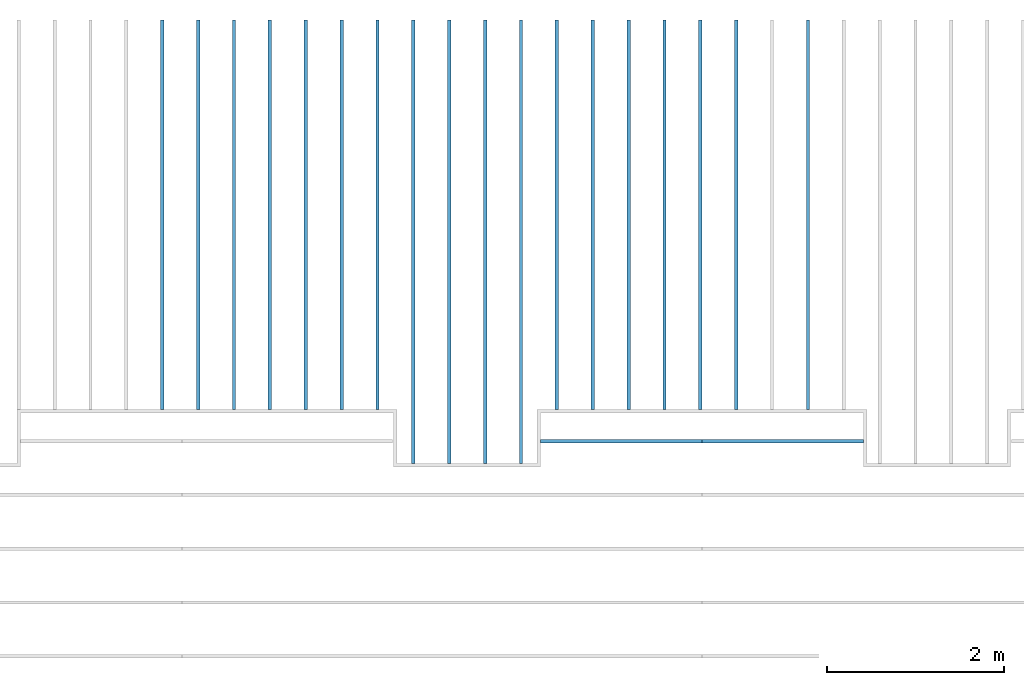
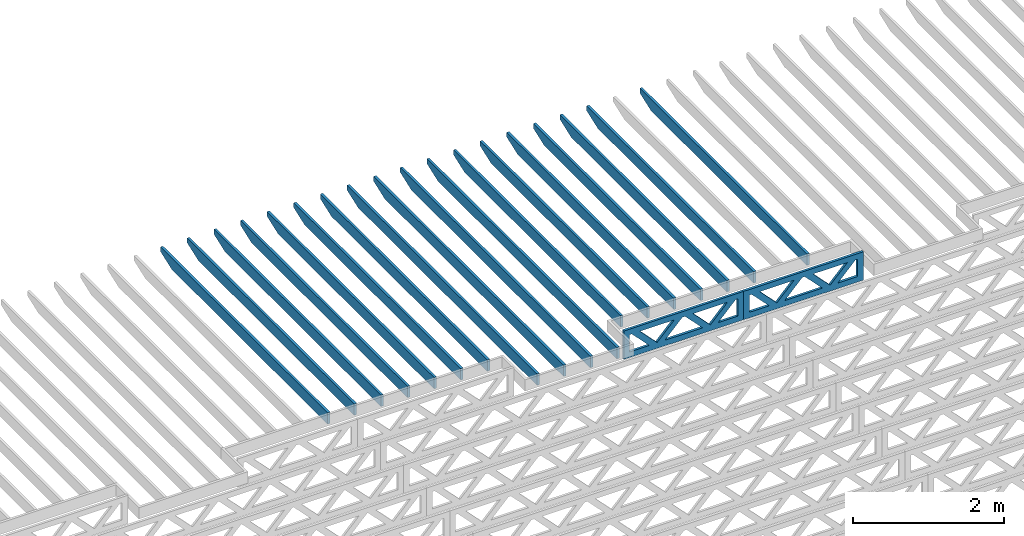
# One storey, part 6 of 18: 20 beams, 3 elements without a shape of their own.
"""IFC4 building model written with IfcOpenShell, lengths in feet."""

from ifc_helpers import new_model, entity, si_unit, converted_unit, derived_unit, direction, frame, frame_2d, origin, origin_2d_with_axis, place, context, subcontext, project, spatial, rectangle, extrude, clip, halfspace, source, transform, mapped, material, material_profile, profile_set, profile_usage, type_object, type_shapes, element, aggregate, save


model = new_model("IFC4")

# Units and contexts
model_context_1 = context("Model", 3, precision=0.0001, world=origin(), true_north=direction((6.12303176911189e-17, 1.0)))
model_context_2 = context("Model", 3, precision=0.0001, world=origin(), true_north=direction((6.12303176911189e-17, 1.0)))
body_context = subcontext(model_context_2, "Body", "Model", "MODEL_VIEW")
ifc_project = project(units=[converted_unit("LENGTHUNIT", "FOOT", entity("IfcRatioMeasure", 0.3048), si_unit("LENGTHUNIT", "METRE"), dimensions=[1, 0, 0, 0, 0, 0, 0]), converted_unit("AREAUNIT", "SQUARE FOOT", entity("IfcRatioMeasure", 0.09290304), si_unit("AREAUNIT", "SQUARE_METRE"), dimensions=[2, 0, 0, 0, 0, 0, 0]), converted_unit("VOLUMEUNIT", "CUBIC FOOT", entity("IfcRatioMeasure", 0.028316846592), si_unit("VOLUMEUNIT", "CUBIC_METRE"), dimensions=[3, 0, 0, 0, 0, 0, 0]), converted_unit("PLANEANGLEUNIT", "DEGREE", entity("IfcRatioMeasure", 0.0174532925199433), si_unit("PLANEANGLEUNIT", "RADIAN"), dimensions=[0, 0, 0, 0, 0, 0, 0]), si_unit("MASSUNIT", "GRAM", prefix="KILO"), derived_unit("MASSDENSITYUNIT", [(si_unit("MASSUNIT", "GRAM", prefix="KILO"), 1), (si_unit("LENGTHUNIT", "METRE"), -3)]), derived_unit("MOMENTOFINERTIAUNIT", [(si_unit("LENGTHUNIT", "METRE"), 4)]), si_unit("TIMEUNIT", "SECOND"), si_unit("FREQUENCYUNIT", "HERTZ"), si_unit("THERMODYNAMICTEMPERATUREUNIT", "DEGREE_CELSIUS"), derived_unit("THERMALTRANSMITTANCEUNIT", [(si_unit("MASSUNIT", "GRAM", prefix="KILO"), 1), (si_unit("THERMODYNAMICTEMPERATUREUNIT", "KELVIN"), -1), (si_unit("TIMEUNIT", "SECOND"), -3)]), derived_unit("VOLUMETRICFLOWRATEUNIT", [(si_unit("LENGTHUNIT", "METRE"), 3), (si_unit("TIMEUNIT", "SECOND"), -1)]), si_unit("ELECTRICCURRENTUNIT", "AMPERE"), si_unit("ELECTRICVOLTAGEUNIT", "VOLT"), si_unit("POWERUNIT", "WATT"), si_unit("FORCEUNIT", "NEWTON"), si_unit("ILLUMINANCEUNIT", "LUX"), si_unit("LUMINOUSFLUXUNIT", "LUMEN"), si_unit("LUMINOUSINTENSITYUNIT", "CANDELA"), derived_unit("USERDEFINED", [(si_unit("MASSUNIT", "GRAM", prefix="KILO"), -1), (si_unit("LENGTHUNIT", "METRE"), -2), (si_unit("TIMEUNIT", "SECOND"), 3), (si_unit("LUMINOUSFLUXUNIT", "LUMEN"), 1)]), derived_unit("LINEARVELOCITYUNIT", [(si_unit("LENGTHUNIT", "METRE"), 1), (si_unit("TIMEUNIT", "SECOND"), -1)]), si_unit("PRESSUREUNIT", "PASCAL"), derived_unit("USERDEFINED", [(si_unit("LENGTHUNIT", "METRE"), -2), (si_unit("MASSUNIT", "GRAM", prefix="KILO"), 1), (si_unit("TIMEUNIT", "SECOND"), -2)]), derived_unit("LINEARFORCEUNIT", [(si_unit("MASSUNIT", "GRAM", prefix="KILO"), 1), (si_unit("LENGTHUNIT", "METRE"), 1), (si_unit("TIMEUNIT", "SECOND"), -2), (si_unit("LENGTHUNIT", "METRE"), -1)]), derived_unit("PLANARFORCEUNIT", [(si_unit("MASSUNIT", "GRAM", prefix="KILO"), 1), (si_unit("LENGTHUNIT", "METRE"), 1), (si_unit("TIMEUNIT", "SECOND"), -2), (si_unit("LENGTHUNIT", "METRE"), -2)])], contexts=[model_context_1])

# Site, building, storey
site_placement = place(None, origin())
site = spatial("IfcSite", under=ifc_project, at=site_placement, CompositionType="ELEMENT")
building_placement = place(site_placement, origin())
building = spatial("IfcBuilding", under=site, at=building_placement, CompositionType="ELEMENT")
storey_placement = place(building_placement, frame((0.0, 0.0, 30.4375000000082)))
storey = spatial("IfcBuildingStorey", under=building, at=storey_placement, Name="ROOF", CompositionType="ELEMENT", Elevation=30.4375000000082)

# Assembly, beam
assembly_1_placement = place(storey_placement, origin())
assembly_1 = element("IfcElementAssembly", 1, at=assembly_1_placement, inside=storey, Name="Structural Beam System:Structural Framing System", ObjectType="Structural Beam System:Structural Framing System", AssemblyPlace="NOTDEFINED", PredefinedType="BEAM_GRID")
ifc_material_1 = material(Name="WOOD TRUSS", Category="Materials")
ifc_material_profile_1 = material_profile(ifc_material_1, rectangle(XDim=1.73473973950632, YDim=0.125, at=origin_2d_with_axis()))
ifc_material_profile_2 = material_profile(ifc_material_1, rectangle(XDim=1.73473973950633, YDim=0.125, at=frame_2d((-1.11022302462516e-16, 0.0), x_axis=(1.0, 0.0))))
ifc_material_profile_3 = material_profile(ifc_material_1, rectangle(XDim=1.73473973950632, YDim=0.125, at=origin_2d_with_axis()))
ifc_material_profile_4 = material_profile(ifc_material_1, rectangle(XDim=1.73473973950633, YDim=0.125, at=origin_2d_with_axis()))
ifc_material_profile_5 = material_profile(ifc_material_1, rectangle(XDim=1.73473973950632, YDim=0.125, at=frame_2d((-5.55111512312578e-17, 0.0), x_axis=(1.0, 0.0))))
ifc_material_profile_6 = material_profile(ifc_material_1, rectangle(XDim=1.73473973950633, YDim=0.125, at=frame_2d((-2.77555756156289e-16, 0.0), x_axis=(1.0, 0.0))))
ifc_material_profile_7 = material_profile(ifc_material_1, rectangle(XDim=1.73473973950632, YDim=0.125, at=frame_2d((-4.9960036108132e-16, 0.0), x_axis=(1.0, 0.0))))
ifc_material_profile_8 = material_profile(ifc_material_1, rectangle(XDim=1.73473973950633, YDim=0.125, at=frame_2d((4.44089209850063e-16, 0.0), x_axis=(1.0, 0.0))))
ifc_material_profile_9 = material_profile(ifc_material_1, rectangle(XDim=1.73473973950632, YDim=0.125, at=origin_2d_with_axis()))
ifc_material_profile_10 = material_profile(ifc_material_1, rectangle(XDim=1.73473973950633, YDim=0.125, at=frame_2d((-4.9960036108132e-16, 0.0), x_axis=(1.0, 0.0))))
ifc_material_profile_11 = material_profile(ifc_material_1, rectangle(XDim=0.291666666666664, YDim=0.125, at=frame_2d((-2.77555756156289e-17, 0.0), x_axis=(1.0, 0.0))))
ifc_material_profile_12 = material_profile(ifc_material_1, rectangle(XDim=0.291666666666628, YDim=0.124999999999995, at=frame_2d((-5.55111512312578e-17, 0.0), x_axis=(1.0, 0.0))))
ifc_material_profile_13 = material_profile(ifc_material_1, rectangle(XDim=0.916666666666666, YDim=0.125000000000003, at=frame_2d((-2.77555756156289e-17, 0.0), x_axis=(1.0, 0.0))))
ifc_material_profile_14 = material_profile(ifc_material_1, rectangle(XDim=0.916666666666651, YDim=0.125, at=frame_2d((-2.77555756156289e-17, 0.0), x_axis=(1.0, 0.0))))
ifc_profile_set_1 = profile_set([ifc_material_profile_1, ifc_material_profile_2, ifc_material_profile_3, ifc_material_profile_4, ifc_material_profile_5, ifc_material_profile_6, ifc_material_profile_7, ifc_material_profile_8, ifc_material_profile_9, ifc_material_profile_10, ifc_material_profile_11, ifc_material_profile_12, ifc_material_profile_13, ifc_material_profile_14])
ifc_profile_usage_1 = profile_usage(ifc_profile_set_1, cardinal=8)
beam_type_1 = type_object("IfcBeamType", PredefinedType="BEAM", material=ifc_profile_set_1)
shared_shape_1 = source(origin(), body_context, "Body", "SweptSolid", [
    extrude(rectangle(XDim=1.73473973950632, YDim=0.125, at=frame_2d((5.55111512312578e-17, 0.0), x_axis=(1.0, 0.0))), frame((1.8533931188195, 0.0, 0.101118361020515), z_axis=(0.720569184836762, 0.0, -0.693383046997606), x_axis=(0.693383046997606, 0.0, 0.720569184836762)), (0.0, 0.0, 1.0), 0.291666666666667),
    extrude(rectangle(XDim=1.73473973950633, YDim=0.125, at=frame_2d((-1.11022302462516e-16, 0.0), x_axis=(1.0, 0.0))), frame((0.603107245146231, 0.0, -0.101118361020454), z_axis=(0.720569184836758, 0.0, 0.69338304699761), x_axis=(0.69338304699761, 0.0, -0.720569184836758)), (0.0, 0.0, 1.0), 0.291666666666667),
    extrude(rectangle(XDim=1.73473973950632, YDim=0.125, at=frame_2d((-5.55111512312578e-17, 0.0), x_axis=(1.0, 0.0))), frame((-0.81327325738963, 0.0, 0.101118361020554), z_axis=(0.720569184836762, 0.0, -0.693383046997606), x_axis=(0.693383046997606, 0.0, 0.720569184836762)), (0.0, 0.0, 1.0), 0.291666666666667),
    extrude(rectangle(XDim=1.73473973950633, YDim=0.125, at=frame_2d((-1.66533453693773e-16, 0.0), x_axis=(1.0, 0.0))), frame((-2.0635591310629, 0.0, -0.101118361020415), z_axis=(0.720569184836758, 0.0, 0.69338304699761), x_axis=(0.69338304699761, 0.0, -0.720569184836758)), (0.0, 0.0, 1.0), 0.291666666666666),
    extrude(rectangle(XDim=0.291666666666664, YDim=0.125, at=frame_2d((-2.77555756156289e-17, 0.0), x_axis=(1.0, 0.0))), frame((-2.99999985477115, 0.0, 0.604166666666611), z_axis=(1.0, 0.0, 0.0), x_axis=(0.0, 0.0, -1.0)), (0.0, 0.0, 1.0), 5.99999970954229),
    extrude(rectangle(XDim=0.291666666666628, YDim=0.124999999999995, at=frame_2d((-5.55111512312578e-17, 0.0), x_axis=(1.0, 0.0))), frame((-2.99999985477093, 0.0, -0.604166666666693), z_axis=(1.0, 0.0, 0.0), x_axis=(0.0, 0.0, -1.0)), (0.0, 0.0, 1.0), 5.99999970954208),
    extrude(rectangle(XDim=0.916666666666666, YDim=0.125000000000003, at=frame_2d((-2.77555756156289e-17, 0.0), x_axis=(1.0, 0.0))), frame((2.70833318810446, 0.0, 0.0), z_axis=(1.0, 0.0, 0.0), x_axis=(0.0, 0.0, -1.0)), (0.0, 0.0, 1.0), 0.291666666666687),
    extrude(rectangle(XDim=0.916666666666651, YDim=0.125, at=frame_2d((-2.77555756156289e-17, 0.0), x_axis=(1.0, 0.0))), frame((-2.99999985477115, 0.0, 0.0), z_axis=(1.0, 0.0, 0.0), x_axis=(0.0, 0.0, -1.0)), (0.0, 0.0, 1.0), 0.291666666666687),
])
type_shapes(beam_type_1, [shared_shape_1])
beam_1_placement = place(assembly_1_placement, frame((-225.404827006933, 957.861934882651, 0.749999999991608)))
beam_1 = element("IfcBeam", 2, at=beam_1_placement, type_object=beam_type_1, material=ifc_profile_usage_1, PredefinedType="BEAM", context=body_context, shape_type="MappedRepresentation", body=[
    mapped(shared_shape_1, transform((0.0, 0.0, 0.0), scale=1.0)),
])
aggregate(assembly_1, [beam_1])

# Assembly, beams
assembly_2_placement = place(storey_placement, origin())
assembly_2 = element("IfcElementAssembly", 3, at=assembly_2_placement, inside=storey, Name="Structural Beam System:Structural Framing System", ObjectType="Structural Beam System:Structural Framing System", AssemblyPlace="NOTDEFINED", PredefinedType="BEAM_GRID")
ifc_material_2 = material(Name="2X ROOF JOISTS - EXT. STAIN-1 - SEE LIFE SAFETY", Category="Materials")
ifc_material_profile_15 = material_profile(ifc_material_2, rectangle(XDim=0.604166666666667, YDim=0.125000000000011, at=frame_2d((0.0, 0.0), x_axis=(0.0, 1.0))))
ifc_profile_set_2 = profile_set([ifc_material_profile_15])
ifc_profile_usage_2 = profile_usage(ifc_profile_set_2, cardinal=8)
beam_type_2 = type_object("IfcBeamType", PredefinedType="BEAM", material=ifc_profile_set_2)
shared_shape_2 = source(origin(), body_context, "Body", "Clipping", [
    clip(extrude(rectangle(XDim=0.604166666666667, YDim=0.125000000000011, at=frame_2d((0.0, 0.0), x_axis=(0.0, 1.0))), frame((-8.24296473987818, 0.0, 0.0), z_axis=(1.0, 0.0, 0.0), x_axis=(0.0, 1.0, 0.0)), (0.0, 0.0, 1.0), 16.4859294797564), halfspace(frame((-7.26989982048795, -0.0625000000000026, -0.30208333333334), z_axis=(-0.34202014332567, 0.0, -0.939692620785908), x_axis=(0.0, 1.0, 0.0)), False)),
])
type_shapes(beam_type_2, [shared_shape_2])
beam_2_placement = place(assembly_2_placement, frame((-233.133993818795, 965.271566289195, 1.07291666665833), z_axis=(0.0, 0.0, 1.0), x_axis=(0.0, -1.0, 0.0)))
beam_2 = element("IfcBeam", 4, at=beam_2_placement, type_object=beam_type_2, material=ifc_profile_usage_2, PredefinedType="BEAM", context=body_context, shape_type="MappedRepresentation", body=[
    mapped(shared_shape_2, transform((0.0, 0.0, 0.0), scale=1.0)),
])
ifc_profile_usage_3 = profile_usage(ifc_profile_set_2, cardinal=8)
beam_3_placement = place(assembly_2_placement, frame((-231.800660485462, 965.271566289195, 1.07291666665833), z_axis=(0.0, 0.0, 1.0), x_axis=(0.0, -1.0, 0.0)))
beam_3 = element("IfcBeam", 5, at=beam_3_placement, type_object=beam_type_2, material=ifc_profile_usage_3, PredefinedType="BEAM", context=body_context, shape_type="MappedRepresentation", body=[
    mapped(shared_shape_2, transform((0.0, 0.0, 0.0), scale=1.0)),
])
ifc_profile_usage_4 = profile_usage(ifc_profile_set_2, cardinal=8)
beam_4_placement = place(assembly_2_placement, frame((-230.467327152128, 965.271566289195, 1.07291666665833), z_axis=(0.0, 0.0, 1.0), x_axis=(0.0, -1.0, 0.0)))
beam_4 = element("IfcBeam", 6, at=beam_4_placement, type_object=beam_type_2, material=ifc_profile_usage_4, PredefinedType="BEAM", context=body_context, shape_type="MappedRepresentation", body=[
    mapped(shared_shape_2, transform((0.0, 0.0, 0.0), scale=1.0)),
])
ifc_profile_usage_5 = profile_usage(ifc_profile_set_2, cardinal=8)
beam_5_placement = place(assembly_2_placement, frame((-229.133993818795, 965.271566289195, 1.07291666665833), z_axis=(0.0, 0.0, 1.0), x_axis=(0.0, -1.0, 0.0)))
beam_5 = element("IfcBeam", 7, at=beam_5_placement, type_object=beam_type_2, material=ifc_profile_usage_5, PredefinedType="BEAM", context=body_context, shape_type="MappedRepresentation", body=[
    mapped(shared_shape_2, transform((0.0, 0.0, 0.0), scale=1.0)),
])
ifc_profile_usage_6 = profile_usage(ifc_profile_set_2, cardinal=8)
beam_type_3 = type_object("IfcBeamType", PredefinedType="BEAM", material=ifc_profile_set_2)
shared_shape_3 = source(origin(), body_context, "Body", "Clipping", [
    clip(extrude(rectangle(XDim=0.604166666666667, YDim=0.125000000000011, at=frame_2d((0.0, 0.0), x_axis=(0.0, 1.0))), frame((-7.24296400719425, 0.0, 0.0), z_axis=(1.0, 0.0, 0.0), x_axis=(0.0, 1.0, 0.0)), (0.0, 0.0, 1.0), 14.4859280143885), halfspace(frame((-6.26989908780402, -0.0625000000000026, -0.30208333333334), z_axis=(-0.34202014332567, 0.0, -0.939692620785908), x_axis=(0.0, 1.0, 0.0)), False)),
])
type_shapes(beam_type_3, [shared_shape_3])
beam_6_placement = place(assembly_2_placement, frame((-242.467327152128, 966.271567021879, 1.07291666665833), z_axis=(0.0, 0.0, 1.0), x_axis=(0.0, -1.0, 0.0)))
beam_6 = element("IfcBeam", 8, at=beam_6_placement, type_object=beam_type_3, material=ifc_profile_usage_6, PredefinedType="BEAM", context=body_context, shape_type="MappedRepresentation", body=[
    mapped(shared_shape_3, transform((0.0, 0.0, 0.0), scale=1.0)),
])
ifc_profile_usage_7 = profile_usage(ifc_profile_set_2, cardinal=8)
beam_type_4 = type_object("IfcBeamType", PredefinedType="BEAM", material=ifc_profile_set_2)
shared_shape_4 = source(origin(), body_context, "Body", "Clipping", [
    clip(extrude(rectangle(XDim=0.604166666666667, YDim=0.125000000000011, at=frame_2d((0.0, 0.0), x_axis=(0.0, 1.0))), frame((-7.24296417469543, 0.0, 0.0), z_axis=(1.0, 0.0, 0.0), x_axis=(0.0, 1.0, 0.0)), (0.0, 0.0, 1.0), 14.4859283493909), halfspace(frame((-6.2698992553052, -0.0625000000000026, -0.30208333333334), z_axis=(-0.34202014332567, 0.0, -0.939692620785908), x_axis=(0.0, 1.0, 0.0)), False)),
])
type_shapes(beam_type_4, [shared_shape_4])
beam_7_placement = place(assembly_2_placement, frame((-241.133993818795, 966.271566854378, 1.07291666665833), z_axis=(0.0, 0.0, 1.0), x_axis=(0.0, -1.0, 0.0)))
beam_7 = element("IfcBeam", 9, at=beam_7_placement, type_object=beam_type_4, material=ifc_profile_usage_7, PredefinedType="BEAM", context=body_context, shape_type="MappedRepresentation", body=[
    mapped(shared_shape_4, transform((0.0, 0.0, 0.0), scale=1.0)),
])
ifc_profile_usage_8 = profile_usage(ifc_profile_set_2, cardinal=8)
beam_type_5 = type_object("IfcBeamType", PredefinedType="BEAM", material=ifc_profile_set_2)
shared_shape_5 = source(origin(), body_context, "Body", "Clipping", [
    clip(extrude(rectangle(XDim=0.604166666666667, YDim=0.125000000000011, at=frame_2d((0.0, -5.55111512312578e-17), x_axis=(0.0, 1.0))), frame((-7.24296434219661, 0.0, 0.0), z_axis=(1.0, 0.0, 0.0), x_axis=(0.0, 1.0, 0.0)), (0.0, 0.0, 1.0), 14.4859286843932), halfspace(frame((-6.26989942280639, -0.0625000000000026, -0.30208333333334), z_axis=(-0.34202014332567, 0.0, -0.939692620785908), x_axis=(0.0, 1.0, 0.0)), False)),
])
type_shapes(beam_type_5, [shared_shape_5])
beam_8_placement = place(assembly_2_placement, frame((-239.800660485462, 966.271566686877, 1.07291666665833), z_axis=(0.0, 0.0, 1.0), x_axis=(0.0, -1.0, 0.0)))
beam_8 = element("IfcBeam", 10, at=beam_8_placement, type_object=beam_type_5, material=ifc_profile_usage_8, PredefinedType="BEAM", context=body_context, shape_type="MappedRepresentation", body=[
    mapped(shared_shape_5, transform((0.0, 0.0, 0.0), scale=1.0)),
])
ifc_profile_usage_9 = profile_usage(ifc_profile_set_2, cardinal=8)
beam_type_6 = type_object("IfcBeamType", PredefinedType="BEAM", material=ifc_profile_set_2)
shared_shape_6 = source(origin(), body_context, "Body", "Clipping", [
    clip(extrude(rectangle(XDim=0.604166666666667, YDim=0.125000000000011, at=frame_2d((0.0, 0.0), x_axis=(0.0, 1.0))), frame((-7.2429645096978, 0.0, 0.0), z_axis=(1.0, 0.0, 0.0), x_axis=(0.0, 1.0, 0.0)), (0.0, 0.0, 1.0), 14.4859290193956), halfspace(frame((-6.26989959030757, -0.0625000000000026, -0.30208333333334), z_axis=(-0.34202014332567, 0.0, -0.939692620785908), x_axis=(0.0, 1.0, 0.0)), False)),
])
type_shapes(beam_type_6, [shared_shape_6])
beam_9_placement = place(assembly_2_placement, frame((-238.467327152128, 966.271566519376, 1.07291666665833), z_axis=(0.0, 0.0, 1.0), x_axis=(0.0, -1.0, 0.0)))
beam_9 = element("IfcBeam", 11, at=beam_9_placement, type_object=beam_type_6, material=ifc_profile_usage_9, PredefinedType="BEAM", context=body_context, shape_type="MappedRepresentation", body=[
    mapped(shared_shape_6, transform((0.0, 0.0, 0.0), scale=1.0)),
])
ifc_profile_usage_10 = profile_usage(ifc_profile_set_2, cardinal=8)
beam_type_7 = type_object("IfcBeamType", PredefinedType="BEAM", material=ifc_profile_set_2)
shared_shape_7 = source(origin(), body_context, "Body", "Clipping", [
    clip(extrude(rectangle(XDim=0.604166666666667, YDim=0.125000000000011, at=frame_2d((0.0, 0.0), x_axis=(0.0, 1.0))), frame((-7.24296467719893, 0.0, 0.0), z_axis=(1.0, 0.0, 0.0), x_axis=(0.0, 1.0, 0.0)), (0.0, 0.0, 1.0), 14.4859293543979), halfspace(frame((-6.2698997578087, -0.0625000000000026, -0.30208333333334), z_axis=(-0.34202014332567, 0.0, -0.939692620785908), x_axis=(0.0, 1.0, 0.0)), False)),
])
type_shapes(beam_type_7, [shared_shape_7])
beam_10_placement = place(assembly_2_placement, frame((-237.133993818795, 966.271566351875, 1.07291666665833), z_axis=(0.0, 0.0, 1.0), x_axis=(0.0, -1.0, 0.0)))
beam_10 = element("IfcBeam", 12, at=beam_10_placement, type_object=beam_type_7, material=ifc_profile_usage_10, PredefinedType="BEAM", context=body_context, shape_type="MappedRepresentation", body=[
    mapped(shared_shape_7, transform((0.0, 0.0, 0.0), scale=1.0)),
])
ifc_profile_usage_11 = profile_usage(ifc_profile_set_2, cardinal=8)
beam_type_8 = type_object("IfcBeamType", PredefinedType="BEAM", material=ifc_profile_set_2)
shared_shape_8 = source(origin(), body_context, "Body", "Clipping", [
    clip(extrude(rectangle(XDim=0.604166666666667, YDim=0.125000000000011, at=frame_2d((0.0, 0.0), x_axis=(0.0, 1.0))), frame((-7.24296407101895, 0.0, 0.0), z_axis=(1.0, 0.0, 0.0), x_axis=(0.0, 1.0, 0.0)), (0.0, 0.0, 1.0), 14.4859281420379), halfspace(frame((-6.26989915162872, -0.0625000000000026, -0.30208333333334), z_axis=(-0.34202014332567, 0.0, -0.939692620785908), x_axis=(0.0, 1.0, 0.0)), False)),
])
type_shapes(beam_type_8, [shared_shape_8])
beam_11_placement = place(assembly_2_placement, frame((-225.133993818795, 966.271566956687, 1.07291666665832), z_axis=(0.0, 0.0, 1.0), x_axis=(0.0, -1.0, 0.0)))
beam_11 = element("IfcBeam", 13, at=beam_11_placement, type_object=beam_type_8, material=ifc_profile_usage_11, PredefinedType="BEAM", context=body_context, shape_type="MappedRepresentation", body=[
    mapped(shared_shape_8, transform((0.0, 0.0, 0.0), scale=1.0)),
])
ifc_profile_usage_12 = profile_usage(ifc_profile_set_2, cardinal=8)
beam_type_9 = type_object("IfcBeamType", PredefinedType="BEAM", material=ifc_profile_set_2)
shared_shape_9 = source(origin(), body_context, "Body", "Clipping", [
    clip(extrude(rectangle(XDim=0.604166666666667, YDim=0.125000000000011, at=frame_2d((0.0, 0.0), x_axis=(0.0, 1.0))), frame((-7.24296378214677, 0.0, 0.0), z_axis=(1.0, 0.0, 0.0), x_axis=(0.0, 1.0, 0.0)), (0.0, 0.0, 1.0), 14.4859275642935), halfspace(frame((-6.26989886275655, -0.0625000000000026, -0.30208333333334), z_axis=(-0.34202014332567, 0.0, -0.939692620785908), x_axis=(0.0, 1.0, 0.0)), False)),
])
type_shapes(beam_type_9, [shared_shape_9])
beam_12_placement = place(assembly_2_placement, frame((-222.467327152128, 966.271567258212, 1.07291666665832), z_axis=(0.0, 0.0, 1.0), x_axis=(0.0, -1.0, 0.0)))
beam_12 = element("IfcBeam", 14, at=beam_12_placement, type_object=beam_type_9, material=ifc_profile_usage_12, PredefinedType="BEAM", context=body_context, shape_type="MappedRepresentation", body=[
    mapped(shared_shape_9, transform((0.0, 0.0, 0.0), scale=1.0)),
])
ifc_profile_usage_13 = profile_usage(ifc_profile_set_2, cardinal=8)
beam_type_10 = type_object("IfcBeamType", PredefinedType="BEAM", material=ifc_profile_set_2)
shared_shape_10 = source(origin(), body_context, "Body", "Clipping", [
    clip(extrude(rectangle(XDim=0.604166666666667, YDim=0.125000000000011, at=frame_2d((0.0, 0.0), x_axis=(0.0, 1.0))), frame((-7.24296332054621, 0.0, 0.0), z_axis=(1.0, 0.0, 0.0), x_axis=(0.0, 1.0, 0.0)), (0.0, 0.0, 1.0), 14.4859266410924), halfspace(frame((-6.26989840115598, -0.0625000000000026, -0.30208333333334), z_axis=(-0.34202014332567, 0.0, -0.939692620785908), x_axis=(0.0, 1.0, 0.0)), False)),
])
type_shapes(beam_type_10, [shared_shape_10])
beam_13_placement = place(assembly_2_placement, frame((-218.467327152128, 966.2715677105, 1.07291666665832), z_axis=(0.0, 0.0, 1.0), x_axis=(0.0, -1.0, 0.0)))
beam_13 = element("IfcBeam", 15, at=beam_13_placement, type_object=beam_type_10, material=ifc_profile_usage_13, PredefinedType="BEAM", context=body_context, shape_type="MappedRepresentation", body=[
    mapped(shared_shape_10, transform((0.0, 0.0, 0.0), scale=1.0)),
])
ifc_profile_usage_14 = profile_usage(ifc_profile_set_2, cardinal=8)
beam_type_11 = type_object("IfcBeamType", PredefinedType="BEAM", material=ifc_profile_set_2)
shared_shape_11 = source(origin(), body_context, "Body", "Clipping", [
    clip(extrude(rectangle(XDim=0.604166666666667, YDim=0.125000000000011, at=frame_2d((0.0, 0.0), x_axis=(0.0, 1.0))), frame((-7.24296484470017, 0.0, 0.0), z_axis=(1.0, 0.0, 0.0), x_axis=(0.0, 1.0, 0.0)), (0.0, 0.0, 1.0), 14.4859296894003), halfspace(frame((-6.26989992530994, -0.0625000000000026, -0.30208333333334), z_axis=(-0.34202014332567, 0.0, -0.939692620785908), x_axis=(0.0, 1.0, 0.0)), False)),
])
type_shapes(beam_type_11, [shared_shape_11])
beam_14_placement = place(assembly_2_placement, frame((-235.800660485462, 966.271566184373, 1.07291666665833), z_axis=(0.0, 0.0, 1.0), x_axis=(0.0, -1.0, 0.0)))
beam_14 = element("IfcBeam", 16, at=beam_14_placement, type_object=beam_type_11, material=ifc_profile_usage_14, PredefinedType="BEAM", context=body_context, shape_type="MappedRepresentation", body=[
    mapped(shared_shape_11, transform((0.0, 0.0, 0.0), scale=1.0)),
])
ifc_profile_usage_15 = profile_usage(ifc_profile_set_2, cardinal=8)
beam_type_12 = type_object("IfcBeamType", PredefinedType="BEAM", material=ifc_profile_set_2)
shared_shape_12 = source(origin(), body_context, "Body", "Clipping", [
    clip(extrude(rectangle(XDim=0.604166666666667, YDim=0.125000000000011, at=frame_2d((0.0, 0.0), x_axis=(0.0, 1.0))), frame((-7.2429650122013, 0.0, 0.0), z_axis=(1.0, 0.0, 0.0), x_axis=(0.0, 1.0, 0.0)), (0.0, 0.0, 1.0), 14.4859300244026), halfspace(frame((-6.26990009281107, -0.0625000000000026, -0.30208333333334), z_axis=(-0.34202014332567, 0.0, -0.939692620785908), x_axis=(0.0, 1.0, 0.0)), False)),
])
type_shapes(beam_type_12, [shared_shape_12])
beam_15_placement = place(assembly_2_placement, frame((-234.467327152128, 966.271566016872, 1.07291666665833), z_axis=(0.0, 0.0, 1.0), x_axis=(0.0, -1.0, 0.0)))
beam_15 = element("IfcBeam", 17, at=beam_15_placement, type_object=beam_type_12, material=ifc_profile_usage_15, PredefinedType="BEAM", context=body_context, shape_type="MappedRepresentation", body=[
    mapped(shared_shape_12, transform((0.0, 0.0, 0.0), scale=1.0)),
])
ifc_profile_usage_16 = profile_usage(ifc_profile_set_2, cardinal=8)
beam_type_13 = type_object("IfcBeamType", PredefinedType="BEAM", material=ifc_profile_set_2)
shared_shape_13 = source(origin(), body_context, "Body", "Clipping", [
    clip(extrude(rectangle(XDim=0.604166666666667, YDim=0.125000000000011, at=frame_2d((0.0, 0.0), x_axis=(0.0, 1.0))), frame((-7.24296422111348, 0.0, 0.0), z_axis=(1.0, 0.0, 0.0), x_axis=(0.0, 1.0, 0.0)), (0.0, 0.0, 1.0), 14.485928442227), halfspace(frame((-6.26989930172326, -0.0625000000000026, -0.30208333333334), z_axis=(-0.34202014332567, 0.0, -0.939692620785908), x_axis=(0.0, 1.0, 0.0)), False)),
])
type_shapes(beam_type_13, [shared_shape_13])
beam_16_placement = place(assembly_2_placement, frame((-226.467327152128, 966.271566805925, 1.07291666665832), z_axis=(0.0, 0.0, 1.0), x_axis=(0.0, -1.0, 0.0)))
beam_16 = element("IfcBeam", 18, at=beam_16_placement, type_object=beam_type_13, material=ifc_profile_usage_16, PredefinedType="BEAM", context=body_context, shape_type="MappedRepresentation", body=[
    mapped(shared_shape_13, transform((0.0, 0.0, 0.0), scale=1.0)),
])
ifc_profile_usage_17 = profile_usage(ifc_profile_set_2, cardinal=8)
beam_type_14 = type_object("IfcBeamType", PredefinedType="BEAM", material=ifc_profile_set_2)
shared_shape_14 = source(origin(), body_context, "Body", "Clipping", [
    clip(extrude(rectangle(XDim=0.604166666666667, YDim=0.125000000000011, at=frame_2d((0.0, 0.0), x_axis=(0.0, 1.0))), frame((-7.24296392092435, 0.0, 0.0), z_axis=(1.0, 0.0, 0.0), x_axis=(0.0, 1.0, 0.0)), (0.0, 0.0, 1.0), 14.4859278418487), halfspace(frame((-6.26989900153413, -0.0625000000000026, -0.30208333333334), z_axis=(-0.34202014332567, 0.0, -0.939692620785908), x_axis=(0.0, 1.0, 0.0)), False)),
])
type_shapes(beam_type_14, [shared_shape_14])
beam_17_placement = place(assembly_2_placement, frame((-223.800660485462, 966.27156710745, 1.07291666665832), z_axis=(0.0, 0.0, 1.0), x_axis=(0.0, -1.0, 0.0)))
beam_17 = element("IfcBeam", 19, at=beam_17_placement, type_object=beam_type_14, material=ifc_profile_usage_17, PredefinedType="BEAM", context=body_context, shape_type="MappedRepresentation", body=[
    mapped(shared_shape_14, transform((0.0, 0.0, 0.0), scale=1.0)),
])
ifc_profile_usage_18 = profile_usage(ifc_profile_set_2, cardinal=8)
beam_type_15 = type_object("IfcBeamType", PredefinedType="BEAM", material=ifc_profile_set_2)
shared_shape_15 = source(origin(), body_context, "Body", "Clipping", [
    clip(extrude(rectangle(XDim=0.604166666666667, YDim=0.125000000000011, at=frame_2d((0.0, 0.0), x_axis=(0.0, 1.0))), frame((-7.24296361464559, 0.0, 0.0), z_axis=(1.0, 0.0, 0.0), x_axis=(0.0, 1.0, 0.0)), (0.0, 0.0, 1.0), 14.4859272292912), halfspace(frame((-6.26989869525536, -0.0625000000000026, -0.30208333333334), z_axis=(-0.34202014332567, 0.0, -0.939692620785908), x_axis=(0.0, 1.0, 0.0)), False)),
])
type_shapes(beam_type_15, [shared_shape_15])
beam_18_placement = place(assembly_2_placement, frame((-221.133993818795, 966.271567408975, 1.07291666665832), z_axis=(0.0, 0.0, 1.0), x_axis=(0.0, -1.0, 0.0)))
beam_18 = element("IfcBeam", 20, at=beam_18_placement, type_object=beam_type_15, material=ifc_profile_usage_18, PredefinedType="BEAM", context=body_context, shape_type="MappedRepresentation", body=[
    mapped(shared_shape_15, transform((0.0, 0.0, 0.0), scale=1.0)),
])
ifc_profile_usage_19 = profile_usage(ifc_profile_set_2, cardinal=8)
beam_type_16 = type_object("IfcBeamType", PredefinedType="BEAM", material=ifc_profile_set_2)
shared_shape_16 = source(origin(), body_context, "Body", "Clipping", [
    clip(extrude(rectangle(XDim=0.604166666666667, YDim=0.125000000000011, at=frame_2d((0.0, 0.0), x_axis=(0.0, 1.0))), frame((-7.24296437120802, 0.0, 0.0), z_axis=(1.0, 0.0, 0.0), x_axis=(0.0, 1.0, 0.0)), (0.0, 0.0, 1.0), 14.485928742416), halfspace(frame((-6.26989945181779, -0.0625000000000026, -0.30208333333334), z_axis=(-0.34202014332567, 0.0, -0.939692620785908), x_axis=(0.0, 1.0, 0.0)), False)),
])
type_shapes(beam_type_16, [shared_shape_16])
beam_19_placement = place(assembly_2_placement, frame((-227.800660485462, 966.271566655162, 1.07291666665832), z_axis=(0.0, 0.0, 1.0), x_axis=(0.0, -1.0, 0.0)))
beam_19 = element("IfcBeam", 21, at=beam_19_placement, type_object=beam_type_16, material=ifc_profile_usage_19, PredefinedType="BEAM", context=body_context, shape_type="MappedRepresentation", body=[
    mapped(shared_shape_16, transform((0.0, 0.0, 0.0), scale=1.0)),
])
aggregate(assembly_2, [beam_6, beam_7, beam_8, beam_9, beam_10, beam_2, beam_3, beam_4, beam_5, beam_11, beam_12, beam_13, beam_18, beam_17, beam_16, beam_19, beam_15, beam_14])

# Assembly, beam
assembly_3_placement = place(storey_placement, origin())
assembly_3 = element("IfcElementAssembly", 22, at=assembly_3_placement, inside=storey, Name="Structural Beam System:Structural Framing System", ObjectType="Structural Beam System:Structural Framing System", AssemblyPlace="NOTDEFINED", PredefinedType="BEAM_GRID")
ifc_profile_usage_20 = profile_usage(ifc_profile_set_1, cardinal=8)
beam_type_17 = type_object("IfcBeamType", PredefinedType="BEAM", material=ifc_profile_set_1)
shared_shape_17 = source(origin(), body_context, "Body", "SweptSolid", [
    extrude(rectangle(XDim=1.73473973950632, YDim=0.125, at=frame_2d((5.55111512312578e-17, 0.0), x_axis=(1.0, 0.0))), frame((1.85339310373314, 0.0, 0.101118361020515), z_axis=(0.720569184836762, 0.0, -0.693383046997606), x_axis=(0.693383046997606, 0.0, 0.720569184836762)), (0.0, 0.0, 1.0), 0.291666666666667),
    extrude(rectangle(XDim=1.73473973950633, YDim=0.125, at=frame_2d((-1.11022302462516e-16, 0.0), x_axis=(1.0, 0.0))), frame((0.603107230059874, 0.0, -0.101118361020454), z_axis=(0.720569184836758, 0.0, 0.69338304699761), x_axis=(0.69338304699761, 0.0, -0.720569184836758)), (0.0, 0.0, 1.0), 0.291666666666667),
    extrude(rectangle(XDim=1.73473973950632, YDim=0.125, at=frame_2d((-5.55111512312578e-17, 0.0), x_axis=(1.0, 0.0))), frame((-0.813273242303273, 0.0, 0.101118361020554), z_axis=(0.720569184836762, 0.0, -0.693383046997606), x_axis=(0.693383046997606, 0.0, 0.720569184836762)), (0.0, 0.0, 1.0), 0.291666666666667),
    extrude(rectangle(XDim=1.73473973950633, YDim=0.125, at=frame_2d((-1.66533453693773e-16, 0.0), x_axis=(1.0, 0.0))), frame((-2.06355911597654, 0.0, -0.101118361020415), z_axis=(0.720569184836758, 0.0, 0.69338304699761), x_axis=(0.69338304699761, 0.0, -0.720569184836758)), (0.0, 0.0, 1.0), 0.291666666666666),
    extrude(rectangle(XDim=0.291666666666664, YDim=0.125, at=frame_2d((-2.77555756156289e-17, 0.0), x_axis=(1.0, 0.0))), frame((-2.99999983968479, 0.0, 0.604166666666611), z_axis=(1.0, 0.0, 0.0), x_axis=(0.0, 0.0, -1.0)), (0.0, 0.0, 1.0), 5.99999967936958),
    extrude(rectangle(XDim=0.291666666666628, YDim=0.124999999999995, at=frame_2d((-5.55111512312578e-17, 0.0), x_axis=(1.0, 0.0))), frame((-2.99999983968458, 0.0, -0.604166666666693), z_axis=(1.0, 0.0, 0.0), x_axis=(0.0, 0.0, -1.0)), (0.0, 0.0, 1.0), 5.99999967936937),
    extrude(rectangle(XDim=0.916666666666666, YDim=0.125000000000003, at=frame_2d((-2.77555756156289e-17, 0.0), x_axis=(1.0, 0.0))), frame((2.7083331730181, 0.0, 0.0), z_axis=(1.0, 0.0, 0.0), x_axis=(0.0, 0.0, -1.0)), (0.0, 0.0, 1.0), 0.291666666666687),
    extrude(rectangle(XDim=0.916666666666651, YDim=0.125, at=frame_2d((-2.77555756156289e-17, 0.0), x_axis=(1.0, 0.0))), frame((-2.99999983968479, 0.0, 0.0), z_axis=(1.0, 0.0, 0.0), x_axis=(0.0, 0.0, -1.0)), (0.0, 0.0, 1.0), 0.291666666666687),
])
type_shapes(beam_type_17, [shared_shape_17])
beam_20_placement = place(assembly_3_placement, frame((-219.404827312475, 957.861934882651, 0.749999999991601), z_axis=(0.0, 0.0, 1.0), x_axis=(-1.0, 0.0, 0.0)))
beam_20 = element("IfcBeam", 23, at=beam_20_placement, type_object=beam_type_17, material=ifc_profile_usage_20, PredefinedType="BEAM", context=body_context, shape_type="MappedRepresentation", body=[
    mapped(shared_shape_17, transform((0.0, 0.0, 0.0), scale=1.0)),
])
aggregate(assembly_3, [beam_20])

save(model, "model.ifc")
